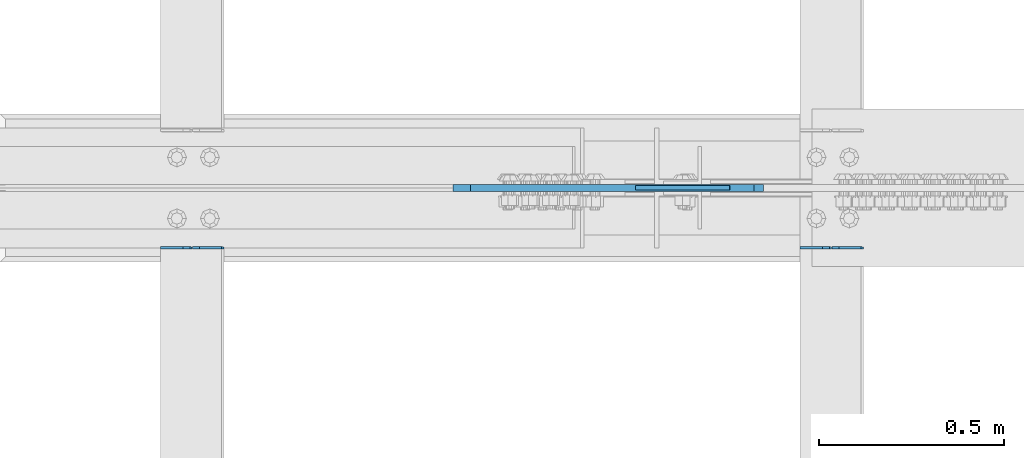
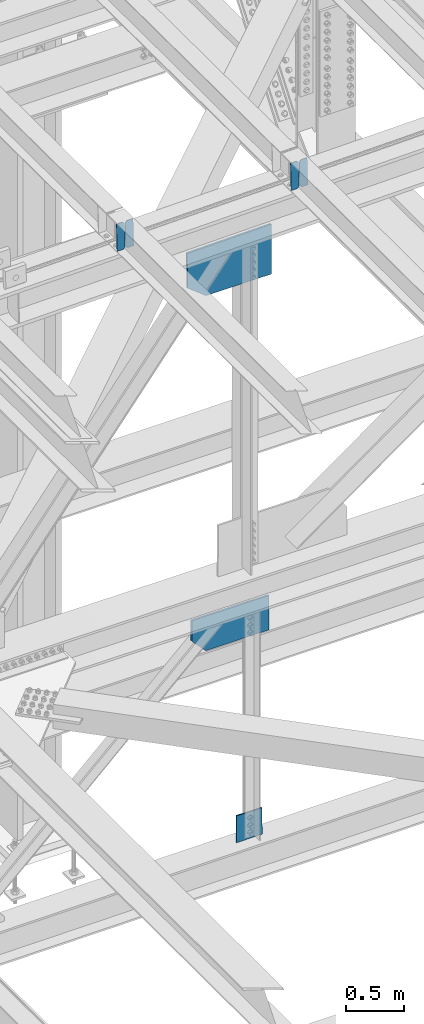
# One storey, part 3616 of 3843: 7 plates, 5 elements without a shape of their own.
"""IFC2X3 building model written with IfcOpenShell, lengths in millimetres."""

from ifc_helpers import new_model, si_unit, frame, origin_with_axes, place, context, subcontext, project, spatial, faceted_brep, material, type_object, element, aggregate, save


model = new_model("IFC2X3")

# Units and contexts
model_context = context("Model", 3, precision=1e-05, world=origin_with_axes())
body_context = subcontext(model_context, "Body", "Model", "MODEL_VIEW")
ifc_project = project(units=[si_unit("LENGTHUNIT", "METRE", prefix="MILLI"), si_unit("AREAUNIT", "SQUARE_METRE"), si_unit("VOLUMEUNIT", "CUBIC_METRE"), si_unit("MASSUNIT", "GRAM", prefix="KILO"), si_unit("TIMEUNIT", "SECOND"), si_unit("PLANEANGLEUNIT", "RADIAN"), si_unit("SOLIDANGLEUNIT", "STERADIAN"), si_unit("THERMODYNAMICTEMPERATUREUNIT", "DEGREE_CELSIUS"), si_unit("LUMINOUSINTENSITYUNIT", "LUMEN")], contexts=[model_context])

# Site, building, storey
site_placement = place(None, origin_with_axes())
site = spatial("IfcSite", under=ifc_project, at=site_placement, CompositionType="ELEMENT")
building_placement = place(site_placement, origin_with_axes())
building = spatial("IfcBuilding", under=site, at=building_placement, Name="Undefined", CompositionType="ELEMENT")
storey_placement = place(building_placement, origin_with_axes())
storey = spatial("IfcBuildingStorey", under=building, at=storey_placement, Name="Undefined", CompositionType="ELEMENT", Elevation=0.0)

# Assembly, plates
assembly_1_placement = place(storey_placement, origin_with_axes())
assembly_1 = element("IfcElementAssembly", 1, at=assembly_1_placement, inside=storey, Name="BEAM", AssemblyPlace="NOTDEFINED", PredefinedType="RIGID_FRAME")
ifc_material = material(Name="STEEL/A572-50")
plate_type_1 = type_object("IfcPlateType", PredefinedType="NOTDEFINED")
plate_1_placement = place(assembly_1_placement, frame((80549.4967116403, 75465.9323145488, 46426.6054811204), z_axis=(-0.021152098224542, 0.00215704300087236, 0.999773942402077), x_axis=(-0.999776269356297, -4.57939999836346e-05, -0.021152048007558)))
plate_1 = element("IfcPlate", 2, at=plate_1_placement, type_object=plate_type_1, material=ifc_material, Name="PLATE", context=body_context, shape_type="Brep", body=[
    faceted_brep([(0.0, -3.17499999999927, 0.0), (6.83940015733242e-10, -3.17499999996653, 288.924999998613), (6.54836185276508e-10, 3.17500000001746, 288.924999998591), (0.0, 3.17499999999927, 0.0), (60.3250007643655, -3.17500000017753, 288.924999998606), (60.3250007643219, 3.17499999979918, 288.924999998584), (79.3750000013097, -3.17500000025029, 269.875000761494), (79.375000001266, 3.17499999972642, 269.875000761487), (79.375000000713, -3.17500000026484, 19.0499992370605), (79.3750000006985, 3.17499999971187, 19.0499992370533), (60.325000763667, -3.17500000020664, -1.45519152283669e-11), (60.3250007636234, 3.17499999977736, -3.63797880709171e-11)], [[[0, 1, 2, 3]], [[1, 4, 5, 2]], [[4, 6, 7, 5]], [[6, 8, 9, 7]], [[8, 10, 11, 9]], [[10, 0, 3, 11]], [[5, 7, 9, 11, 3, 2]], [[10, 8, 6, 4, 1, 0]]]),
])
plate_2_placement = place(assembly_1_placement, frame((80463.790890949, 75465.9284029009, 46424.7922217371), z_axis=(-0.021152098224542, 0.00215704300087236, 0.999773942402077), x_axis=(-0.999776269356297, -4.57939999836346e-05, -0.021152048007558)))
plate_2 = element("IfcPlate", 3, at=plate_2_placement, type_object=plate_type_1, material=ifc_material, Name="PLATE", context=body_context, shape_type="Brep", body=[
    faceted_brep([(4.36557456851006e-11, -3.17499999998836, 19.0499992370969), (6.11180439591408e-10, -3.17499999996653, 269.875000761516), (5.96628524363041e-10, 3.17500000001746, 269.875000761502), (1.45519152283669e-11, 3.17499999998836, 19.0499992370824), (19.0499992376572, -3.17500000003201, 288.924999998606), (19.0499992376281, 3.1749999999447, 288.924999998584), (79.3750000013242, -3.17500000025029, 288.924999998591), (79.3750000013097, 3.1749999997337, 288.92499999857), (79.3750000006548, -3.17500000026484, -2.18278728425503e-11), (79.3750000006403, 3.17499999969732, -2.91038304567337e-11), (19.0499992370023, -3.17500000005384, 0.0), (19.0499992369587, 3.17499999992287, -1.45519152283669e-11)], [[[0, 1, 2, 3]], [[1, 4, 5, 2]], [[4, 6, 7, 5]], [[6, 8, 9, 7]], [[8, 10, 11, 9]], [[10, 0, 3, 11]], [[5, 7, 9, 11, 3, 2]], [[10, 8, 6, 4, 1, 0]]]),
])
aggregate(assembly_1, [plate_1, plate_2])

assembly_2_placement = place(storey_placement, origin_with_axes())
assembly_2 = element("IfcElementAssembly", 4, at=assembly_2_placement, inside=storey, Name="BEAM", AssemblyPlace="NOTDEFINED", PredefinedType="RIGID_FRAME")
plate_3_placement = place(assembly_2_placement, frame((78822.296711667, 75465.9299346179, 46392.8516892137), z_axis=(-0.02115209757931, 0.00216448800069338, 0.999773926325192), x_axis=(-0.999776269356297, -4.57939999836346e-05, -0.021152048007558)))
plate_3 = element("IfcPlate", 5, at=plate_3_placement, type_object=plate_type_1, material=ifc_material, Name="PLATE", context=body_context, shape_type="Brep", body=[
    faceted_brep([(0.0, -3.17499999999927, 0.0), (6.83940015733242e-10, -3.17499999996653, 288.924999998613), (6.54836185276508e-10, 3.17500000001746, 288.924999998591), (0.0, 3.17499999999927, 0.0), (60.3250007643655, -3.17500000017753, 288.924999998606), (60.3250007643219, 3.17499999979918, 288.924999998584), (79.3750000013097, -3.17500000025029, 269.875000761494), (79.375000001266, 3.17499999972642, 269.875000761487), (79.375000000713, -3.17500000026484, 19.0499992370605), (79.3750000006985, 3.17499999971187, 19.0499992370533), (60.325000763667, -3.17500000020664, -1.45519152283669e-11), (60.3250007636234, 3.17499999977736, -3.63797880709171e-11)], [[[0, 1, 2, 3]], [[1, 4, 5, 2]], [[4, 6, 7, 5]], [[6, 8, 9, 7]], [[8, 10, 11, 9]], [[10, 0, 3, 11]], [[5, 7, 9, 11, 3, 2]], [[10, 8, 6, 4, 1, 0]]]),
])
plate_4_placement = place(assembly_2_placement, frame((78736.5908909758, 75465.9260084706, 46391.0384298631), z_axis=(-0.02115209757931, 0.00216448800069338, 0.999773926325192), x_axis=(-0.999776269356297, -4.57939999836346e-05, -0.021152048007558)))
plate_4 = element("IfcPlate", 6, at=plate_4_placement, type_object=plate_type_1, material=ifc_material, Name="PLATE", context=body_context, shape_type="Brep", body=[
    faceted_brep([(4.36557456851006e-11, -3.17499999998836, 19.0499992370969), (6.11180439591408e-10, -3.17499999996653, 269.875000761516), (5.96628524363041e-10, 3.17500000001746, 269.875000761502), (1.45519152283669e-11, 3.17499999998836, 19.0499992370824), (19.0499992376572, -3.17500000003201, 288.924999998606), (19.0499992376281, 3.1749999999447, 288.924999998584), (79.3750000013242, -3.17500000025029, 288.924999998591), (79.3750000013097, 3.1749999997337, 288.92499999857), (79.3750000006548, -3.17500000026484, -2.18278728425503e-11), (79.3750000006403, 3.17499999969732, -2.91038304567337e-11), (19.0499992370023, -3.17500000005384, 0.0), (19.0499992369587, 3.17499999992287, -1.45519152283669e-11)], [[[0, 1, 2, 3]], [[1, 4, 5, 2]], [[4, 6, 7, 5]], [[6, 8, 9, 7]], [[8, 10, 11, 9]], [[10, 0, 3, 11]], [[5, 7, 9, 11, 3, 2]], [[10, 8, 6, 4, 1, 0]]]),
])
aggregate(assembly_2, [plate_3, plate_4])

# Assembly, plate
assembly_3_placement = place(storey_placement, origin_with_axes())
assembly_3 = element("IfcElementAssembly", 7, at=assembly_3_placement, inside=storey, Name="BEAM", AssemblyPlace="NOTDEFINED", PredefinedType="RIGID_FRAME")
plate_type_2 = type_object("IfcPlateType", PredefinedType="NOTDEFINED")
plate_5_placement = place(assembly_3_placement, frame((80279.557505148, 75628.5, 46015.0272766875), z_axis=(0.0190473820031184, 0.0, -0.999818582163198), x_axis=(-0.999818582163198, 0.0, -0.0190473820031122)))
plate_5 = element("IfcPlate", 8, at=plate_5_placement, type_object=plate_type_2, material=ifc_material, Name="PLATE", context=body_context, shape_type="Brep", body=[
    faceted_brep([(0.0, -9.52500000000146, 0.0), (9.65687737773987, -9.52499999999418, 523.572109637847), (9.65687737773987, 9.52499999999418, 523.572109637847), (0.0, 9.52500000000146, 0.0), (661.816780456837, -9.52499999999418, 511.147988326367), (661.816780456837, 9.52499999999418, 511.147988326367), (839.025160492878, -9.52499999999418, 366.734861084209), (839.025160492878, 9.52499999999418, 366.734861084209), (839.025160490666, -9.52499999999418, 8.14907252788544e-10), (839.025160490666, 9.52499999999418, 8.14907252788544e-10)], [[[0, 1, 2, 3]], [[1, 4, 5, 2]], [[4, 6, 7, 5]], [[6, 8, 9, 7]], [[8, 0, 3, 9]], [[5, 7, 9, 3, 2]], [[8, 6, 4, 1, 0]]]),
])
aggregate(assembly_3, [plate_5])

assembly_4_placement = place(storey_placement, origin_with_axes())
assembly_4 = element("IfcElementAssembly", 9, at=assembly_4_placement, inside=storey, Name="BEAM", AssemblyPlace="NOTDEFINED", PredefinedType="RIGID_FRAME")
plate_type_3 = type_object("IfcPlateType", PredefinedType="NOTDEFINED")
plate_6_placement = place(assembly_4_placement, frame((80254.4750003036, 75628.5, 42128.4904339374), z_axis=(-0.0020995939996792, 0.0, -0.999997795850089), x_axis=(-0.999997795850089, 0.0, 0.00209959399968341)))
plate_6 = element("IfcPlate", 10, at=plate_6_placement, type_object=plate_type_3, material=ifc_material, Name="PLATE", context=body_context, shape_type="Brep", body=[
    faceted_brep([(0.0, -9.52500000000146, 0.0), (-0.759540564773488, -9.52499999999418, 361.724332301223), (-0.759540564773488, 9.52499999999418, 361.724332301223), (0.0, 9.52500000000146, 0.0), (626.324045143687, -9.52499999999418, 363.041068219463), (626.324045143687, 9.52499999999418, 363.041068219463), (765.859901165153, -9.52499999999418, 215.325175317048), (765.859901165153, 9.52499999999418, 215.325175317048), (765.859901164818, -9.52499999999418, -1.20053300634027e-09), (765.859901164818, 9.52499999999418, -1.20053300634027e-09)], [[[0, 1, 2, 3]], [[1, 4, 5, 2]], [[4, 6, 7, 5]], [[6, 8, 9, 7]], [[8, 0, 3, 9]], [[5, 7, 9, 3, 2]], [[8, 6, 4, 1, 0]]]),
])
aggregate(assembly_4, [plate_6])

assembly_5_placement = place(storey_placement, origin_with_axes())
assembly_5 = element("IfcElementAssembly", 11, at=assembly_5_placement, inside=storey, Name="BEAM", AssemblyPlace="NOTDEFINED", PredefinedType="RIGID_FRAME")
plate_type_4 = type_object("IfcPlateType", PredefinedType="NOTDEFINED")
plate_7_placement = place(assembly_5_placement, frame((80189.4857720197, 75628.5000007629, 39643.8195171953), z_axis=(-0.00604360400156291, 0.0, 0.999981737258572), x_axis=(-0.999981737258572, 0.0, -0.00604360400156005)))
plate_7 = element("IfcPlate", 12, at=plate_7_placement, type_object=plate_type_4, material=ifc_material, Name="PLATE", context=body_context, shape_type="Brep", body=[
    faceted_brep([(0.0, -6.3499999046162, 0.0), (1.68802216649055e-09, -6.35000000000582, 278.934838651556), (1.68802216649055e-09, 6.35000000000582, 278.934838651556), (7.27595761418343e-12, 6.3499999046162, 0.0), (253.995361635985, -6.35000000000582, 280.469914072346), (253.995361635985, 6.35000000000582, 280.469914072346), (255.690441688173, -6.35000000000582, 3.34694050252438e-10), (255.690441688173, 6.35000000000582, 3.34694050252438e-10)], [[[0, 1, 2, 3]], [[1, 4, 5, 2]], [[4, 6, 7, 5]], [[6, 0, 3, 7]], [[5, 7, 3, 2]], [[6, 4, 1, 0]]]),
])
aggregate(assembly_5, [plate_7])

save(model, "model.ifc")
